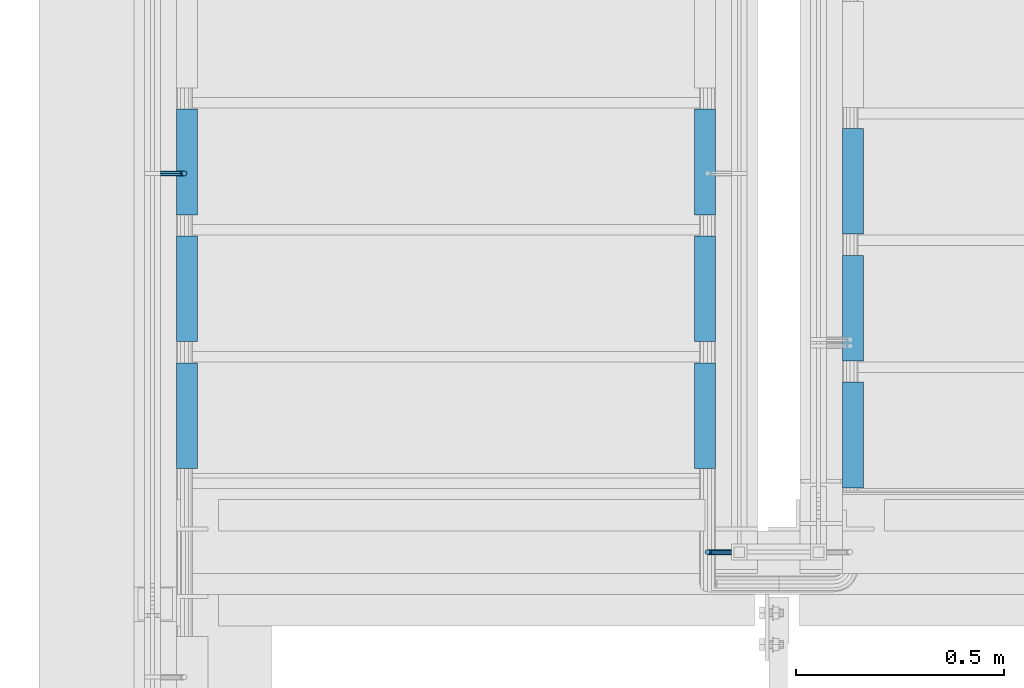
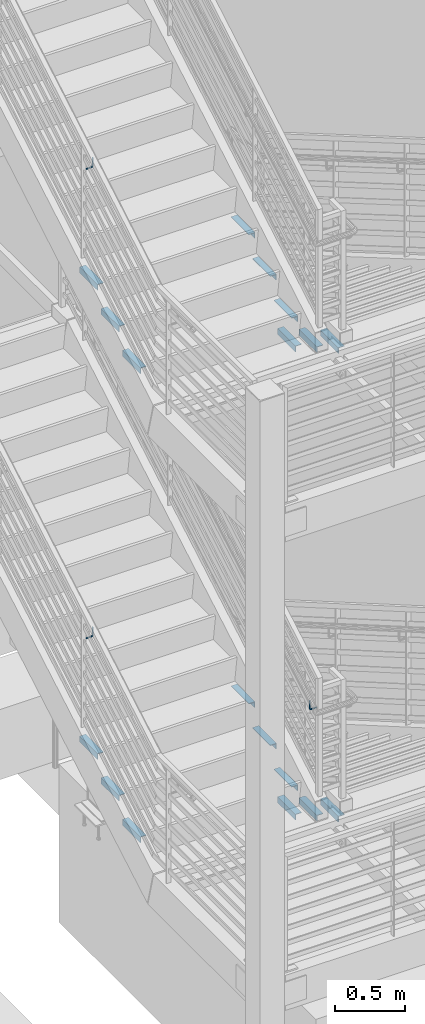
# One storey, part 857 of 1179: 21 beams, 7 elements without a shape of their own.
"""IFC2X3 building model written with IfcOpenShell, lengths in millimetres."""

from ifc_helpers import new_model, si_unit, frame, origin_with_axes, place, context, subcontext, project, spatial, faceted_brep, material, type_object, element, aggregate, save


model = new_model("IFC2X3")

# Units and contexts
model_context = context("Model", 3, precision=1e-05, world=origin_with_axes())
body_context = subcontext(model_context, "Body", "Model", "MODEL_VIEW")
ifc_project = project(units=[si_unit("LENGTHUNIT", "METRE", prefix="MILLI"), si_unit("AREAUNIT", "SQUARE_METRE"), si_unit("VOLUMEUNIT", "CUBIC_METRE"), si_unit("MASSUNIT", "GRAM", prefix="KILO"), si_unit("TIMEUNIT", "SECOND"), si_unit("PLANEANGLEUNIT", "RADIAN"), si_unit("SOLIDANGLEUNIT", "STERADIAN"), si_unit("THERMODYNAMICTEMPERATUREUNIT", "DEGREE_CELSIUS"), si_unit("LUMINOUSINTENSITYUNIT", "LUMEN")], contexts=[model_context])

# Site, building, storey
site_placement = place(None, origin_with_axes())
site = spatial("IfcSite", under=ifc_project, at=site_placement, CompositionType="ELEMENT")
building_placement = place(site_placement, origin_with_axes())
building = spatial("IfcBuilding", under=site, at=building_placement, Name="Undefined", CompositionType="ELEMENT")
storey_placement = place(building_placement, origin_with_axes())
storey = spatial("IfcBuildingStorey", under=building, at=storey_placement, Name="Undefined", CompositionType="ELEMENT", Elevation=0.0)

# Assembly, beams
assembly_1_placement = place(storey_placement, origin_with_axes())
assembly_1 = element("IfcElementAssembly", 1, at=assembly_1_placement, inside=storey, Name="STRINGER", AssemblyPlace="NOTDEFINED", PredefinedType="RIGID_FRAME")
ifc_material = material(Name="STEEL/A36")
beam_type_1 = type_object("IfcBeamType", Name="L2X2X3/16", PredefinedType="NOTDEFINED")
beam_1_placement = place(assembly_1_placement, frame((-3174.9999999819, 32547.8643790635, 6645.27500000067), z_axis=(1.0, 0.0, 0.0), x_axis=(0.0, 1.0, 0.0)))
beam_1 = element("IfcBeam", 2, at=beam_1_placement, type_object=beam_type_1, material=ifc_material, Name="ANGLE", ObjectType="L2X2X3/16", context=body_context, shape_type="Brep", body=[
    faceted_brep([(0.0, 25.3999999999996, -25.4000000000015), (0.0, 25.3999999999996, 25.4000000000015), (254.0, 25.3999999999996, 25.4000000000001), (254.0, 25.3999999999996, -25.4000000000001), (0.0, 20.6374999999998, 25.4000000000015), (254.0, 20.6374999999998, 25.4000000000001), (0.0, 20.6374999999998, -20.6374999999971), (254.0, 20.6374999999998, -20.6374999999998), (0.0, -25.3999999999996, -20.6374999999971), (254.0, -25.3999999999996, -20.6374999999998), (0.0, -25.3999999999996, -25.4000000000015), (254.0, -25.3999999999996, -25.4000000000001)], [[[0, 1, 2, 3]], [[1, 4, 5, 2]], [[4, 6, 7, 5]], [[6, 8, 9, 7]], [[8, 10, 11, 9]], [[10, 0, 3, 11]], [[5, 7, 9, 11, 3, 2]], [[10, 8, 6, 4, 1, 0]]]),
])
beam_2_placement = place(assembly_1_placement, frame((-1930.40000000111, 32801.8643790635, 6645.27499999953), z_axis=(-1.0, 0.0, 0.0), x_axis=(0.0, -1.0, 0.0)))
beam_2 = element("IfcBeam", 3, at=beam_2_placement, type_object=beam_type_1, material=ifc_material, Name="ANGLE", ObjectType="L2X2X3/16", context=body_context, shape_type="Brep", body=[
    faceted_brep([(0.0, 25.3999999999996, -25.4000000000015), (0.0, 25.3999999999996, 25.4000000000015), (254.0, 25.3999999999996, 25.4000000000001), (254.0, 25.3999999999996, -25.4000000000001), (0.0, 20.6374999999998, 25.4000000000015), (254.0, 20.6374999999998, 25.4000000000001), (0.0, 20.6374999999998, -20.6374999999971), (254.0, 20.6374999999998, -20.6374999999998), (0.0, -25.3999999999996, -20.6374999999971), (254.0, -25.3999999999996, -20.6374999999998), (0.0, -25.3999999999996, -25.4000000000015), (254.0, -25.3999999999996, -25.4000000000001)], [[[0, 1, 2, 3]], [[1, 4, 5, 2]], [[4, 6, 7, 5]], [[6, 8, 9, 7]], [[8, 10, 11, 9]], [[10, 0, 3, 11]], [[5, 7, 9, 11, 3, 2]], [[10, 8, 6, 4, 1, 0]]]),
])
beam_3_placement = place(assembly_1_placement, frame((-3174.99999998206, 32243.0643793155, 6467.47500000067), z_axis=(1.0, 0.0, 0.0), x_axis=(0.0, 1.0, 0.0)))
beam_3 = element("IfcBeam", 4, at=beam_3_placement, type_object=beam_type_1, material=ifc_material, Name="ANGLE", ObjectType="L2X2X3/16", context=body_context, shape_type="Brep", body=[
    faceted_brep([(0.0, 25.3999999999996, -25.4000000000015), (0.0, 25.3999999999996, 25.4000000000015), (254.0, 25.3999999999996, 25.4000000000001), (254.0, 25.3999999999996, -25.4000000000001), (0.0, 20.6374999999998, 25.4000000000015), (254.0, 20.6374999999998, 25.4000000000001), (0.0, 20.6374999999998, -20.6374999999971), (254.0, 20.6374999999998, -20.6374999999998), (0.0, -25.3999999999996, -20.6374999999971), (254.0, -25.3999999999996, -20.6374999999998), (0.0, -25.3999999999996, -25.4000000000015), (254.0, -25.3999999999996, -25.4000000000001)], [[[0, 1, 2, 3]], [[1, 4, 5, 2]], [[4, 6, 7, 5]], [[6, 8, 9, 7]], [[8, 10, 11, 9]], [[10, 0, 3, 11]], [[5, 7, 9, 11, 3, 2]], [[10, 8, 6, 4, 1, 0]]]),
])
beam_4_placement = place(assembly_1_placement, frame((-1930.40000000127, 32497.0643793156, 6467.47499999953), z_axis=(-1.0, 0.0, 0.0), x_axis=(0.0, -1.0, 0.0)))
beam_4 = element("IfcBeam", 5, at=beam_4_placement, type_object=beam_type_1, material=ifc_material, Name="ANGLE", ObjectType="L2X2X3/16", context=body_context, shape_type="Brep", body=[
    faceted_brep([(0.0, 25.3999999999996, -25.4000000000015), (0.0, 25.3999999999996, 25.4000000000015), (254.0, 25.3999999999996, 25.4000000000001), (254.0, 25.3999999999996, -25.4000000000001), (0.0, 20.6374999999998, 25.4000000000015), (254.0, 20.6374999999998, 25.4000000000001), (0.0, 20.6374999999998, -20.6374999999971), (254.0, 20.6374999999998, -20.6374999999998), (0.0, -25.3999999999996, -20.6374999999971), (254.0, -25.3999999999996, -20.6374999999998), (0.0, -25.3999999999996, -25.4000000000015), (254.0, -25.3999999999996, -25.4000000000001)], [[[0, 1, 2, 3]], [[1, 4, 5, 2]], [[4, 6, 7, 5]], [[6, 8, 9, 7]], [[8, 10, 11, 9]], [[10, 0, 3, 11]], [[5, 7, 9, 11, 3, 2]], [[10, 8, 6, 4, 1, 0]]]),
])
beam_5_placement = place(assembly_1_placement, frame((-3174.99999998222, 31938.2643795676, 6289.67500000067), z_axis=(1.0, 0.0, 0.0), x_axis=(0.0, 1.0, 0.0)))
beam_5 = element("IfcBeam", 6, at=beam_5_placement, type_object=beam_type_1, material=ifc_material, Name="ANGLE", ObjectType="L2X2X3/16", context=body_context, shape_type="Brep", body=[
    faceted_brep([(0.0, 25.3999999999996, -25.4000000000015), (0.0, 25.3999999999996, 25.4000000000015), (254.0, 25.3999999999996, 25.4000000000001), (254.0, 25.3999999999996, -25.4000000000001), (0.0, 20.6374999999998, 25.4000000000015), (254.0, 20.6374999999998, 25.4000000000001), (0.0, 20.6374999999998, -20.6374999999971), (254.0, 20.6374999999998, -20.6374999999998), (0.0, -25.3999999999996, -20.6374999999971), (254.0, -25.3999999999996, -20.6374999999998), (0.0, -25.3999999999996, -25.4000000000015), (254.0, -25.3999999999996, -25.4000000000001)], [[[0, 1, 2, 3]], [[1, 4, 5, 2]], [[4, 6, 7, 5]], [[6, 8, 9, 7]], [[8, 10, 11, 9]], [[10, 0, 3, 11]], [[5, 7, 9, 11, 3, 2]], [[10, 8, 6, 4, 1, 0]]]),
])
beam_6_placement = place(assembly_1_placement, frame((-1930.40000000143, 32192.2643795676, 6289.67499999953), z_axis=(-1.0, 0.0, 0.0), x_axis=(0.0, -1.0, 0.0)))
beam_6 = element("IfcBeam", 7, at=beam_6_placement, type_object=beam_type_1, material=ifc_material, Name="ANGLE", ObjectType="L2X2X3/16", context=body_context, shape_type="Brep", body=[
    faceted_brep([(0.0, 25.3999999999996, -25.4000000000015), (0.0, 25.3999999999996, 25.4000000000015), (254.0, 25.3999999999996, 25.4000000000001), (254.0, 25.3999999999996, -25.4000000000001), (0.0, 20.6374999999998, 25.4000000000015), (254.0, 20.6374999999998, 25.4000000000001), (0.0, 20.6374999999998, -20.6374999999971), (254.0, 20.6374999999998, -20.6374999999998), (0.0, -25.3999999999996, -20.6374999999971), (254.0, -25.3999999999996, -20.6374999999998), (0.0, -25.3999999999996, -25.4000000000015), (254.0, -25.3999999999996, -25.4000000000001)], [[[0, 1, 2, 3]], [[1, 4, 5, 2]], [[4, 6, 7, 5]], [[6, 8, 9, 7]], [[8, 10, 11, 9]], [[10, 0, 3, 11]], [[5, 7, 9, 11, 3, 2]], [[10, 8, 6, 4, 1, 0]]]),
])
aggregate(assembly_1, [beam_1, beam_2, beam_3, beam_4, beam_5, beam_6])

assembly_2_placement = place(storey_placement, origin_with_axes())
assembly_2 = element("IfcElementAssembly", 8, at=assembly_2_placement, inside=storey, Name="STRINGER", AssemblyPlace="NOTDEFINED", PredefinedType="RIGID_FRAME")
beam_7_placement = place(assembly_2_placement, frame((-1574.79999998749, 31891.9356228005, 5934.07499988841), z_axis=(1.0, 0.0, 0.0), x_axis=(0.0, 1.0, 0.0)))
beam_7 = element("IfcBeam", 9, at=beam_7_placement, type_object=beam_type_1, material=ifc_material, Name="ANGLE", ObjectType="L2X2X3/16", context=body_context, shape_type="Brep", body=[
    faceted_brep([(0.0, 25.3999999999996, -25.4000000000015), (0.0, 25.3999999999996, 25.4000000000015), (254.0, 25.3999999999996, 25.4000000000001), (254.0, 25.3999999999996, -25.4000000000001), (0.0, 20.6374999999998, 25.4000000000015), (254.0, 20.6374999999998, 25.4000000000001), (0.0, 20.6374999999998, -20.6374999999971), (254.0, 20.6374999999998, -20.6374999999998), (0.0, -25.3999999999996, -20.6374999999971), (254.0, -25.3999999999996, -20.6374999999998), (0.0, -25.3999999999996, -25.4000000000015), (254.0, -25.3999999999996, -25.4000000000001)], [[[0, 1, 2, 3]], [[1, 4, 5, 2]], [[4, 6, 7, 5]], [[6, 8, 9, 7]], [[8, 10, 11, 9]], [[10, 0, 3, 11]], [[5, 7, 9, 11, 3, 2]], [[10, 8, 6, 4, 1, 0]]]),
])
beam_8_placement = place(assembly_2_placement, frame((-1574.79999998955, 32196.7356227365, 5756.27499977871), z_axis=(1.0, 0.0, 0.0), x_axis=(0.0, 1.0, 0.0)))
beam_8 = element("IfcBeam", 10, at=beam_8_placement, type_object=beam_type_1, material=ifc_material, Name="ANGLE", ObjectType="L2X2X3/16", context=body_context, shape_type="Brep", body=[
    faceted_brep([(0.0, 25.3999999999996, -25.4000000000015), (0.0, 25.3999999999996, 25.4000000000015), (254.0, 25.3999999999996, 25.4000000000001), (254.0, 25.3999999999996, -25.4000000000001), (0.0, 20.6374999999998, 25.4000000000015), (254.0, 20.6374999999998, 25.4000000000001), (0.0, 20.6374999999998, -20.6374999999971), (254.0, 20.6374999999998, -20.6374999999998), (0.0, -25.3999999999996, -20.6374999999971), (254.0, -25.3999999999996, -20.6374999999998), (0.0, -25.3999999999996, -25.4000000000015), (254.0, -25.3999999999996, -25.4000000000001)], [[[0, 1, 2, 3]], [[1, 4, 5, 2]], [[4, 6, 7, 5]], [[6, 8, 9, 7]], [[8, 10, 11, 9]], [[10, 0, 3, 11]], [[5, 7, 9, 11, 3, 2]], [[10, 8, 6, 4, 1, 0]]]),
])
beam_9_placement = place(assembly_2_placement, frame((-1574.7999999916, 32501.5356226725, 5578.47499966901), z_axis=(1.0, 0.0, 0.0), x_axis=(0.0, 1.0, 0.0)))
beam_9 = element("IfcBeam", 11, at=beam_9_placement, type_object=beam_type_1, material=ifc_material, Name="ANGLE", ObjectType="L2X2X3/16", context=body_context, shape_type="Brep", body=[
    faceted_brep([(0.0, 25.3999999999996, -25.4000000000015), (0.0, 25.3999999999996, 25.4000000000015), (254.0, 25.3999999999996, 25.4000000000001), (254.0, 25.3999999999996, -25.4000000000001), (0.0, 20.6374999999998, 25.4000000000015), (254.0, 20.6374999999998, 25.4000000000001), (0.0, 20.6374999999998, -20.6374999999971), (254.0, 20.6374999999998, -20.6374999999998), (0.0, -25.3999999999996, -20.6374999999971), (254.0, -25.3999999999996, -20.6374999999998), (0.0, -25.3999999999996, -25.4000000000015), (254.0, -25.3999999999996, -25.4000000000001)], [[[0, 1, 2, 3]], [[1, 4, 5, 2]], [[4, 6, 7, 5]], [[6, 8, 9, 7]], [[8, 10, 11, 9]], [[10, 0, 3, 11]], [[5, 7, 9, 11, 3, 2]], [[10, 8, 6, 4, 1, 0]]]),
])
aggregate(assembly_2, [beam_7, beam_8, beam_9])

assembly_3_placement = place(storey_placement, origin_with_axes())
assembly_3 = element("IfcElementAssembly", 12, at=assembly_3_placement, inside=storey, Name="STRINGER", AssemblyPlace="NOTDEFINED", PredefinedType="RIGID_FRAME")
beam_10_placement = place(assembly_3_placement, frame((-1574.79999997975, 31891.8810167866, 1861.92102470219), z_axis=(1.0, 0.0, 0.0), x_axis=(0.0, 1.0, 0.0)))
beam_10 = element("IfcBeam", 13, at=beam_10_placement, type_object=beam_type_1, material=ifc_material, Name="ANGLE", ObjectType="L2X2X3/16", context=body_context, shape_type="Brep", body=[
    faceted_brep([(0.0, 25.3999999999996, -25.4000000000015), (0.0, 25.3999999999996, 25.4000000000015), (254.0, 25.3999999999996, 25.4000000000001), (254.0, 25.3999999999996, -25.4000000000001), (0.0, 20.6374999999998, 25.4000000000015), (254.0, 20.6374999999998, 25.4000000000001), (0.0, 20.6374999999998, -20.6374999999971), (254.0, 20.6374999999998, -20.6374999999998), (0.0, -25.3999999999996, -20.6374999999971), (254.0, -25.3999999999996, -20.6374999999998), (0.0, -25.3999999999996, -25.4000000000015), (254.0, -25.3999999999996, -25.4000000000001)], [[[0, 1, 2, 3]], [[1, 4, 5, 2]], [[4, 6, 7, 5]], [[6, 8, 9, 7]], [[8, 10, 11, 9]], [[10, 0, 3, 11]], [[5, 7, 9, 11, 3, 2]], [[10, 8, 6, 4, 1, 0]]]),
])
beam_11_placement = place(assembly_3_placement, frame((-1574.7999999797, 32196.6811705206, 1685.43913056506), z_axis=(1.0, 0.0, 0.0), x_axis=(0.0, 1.0, 0.0)))
beam_11 = element("IfcBeam", 14, at=beam_11_placement, type_object=beam_type_1, material=ifc_material, Name="ANGLE", ObjectType="L2X2X3/16", context=body_context, shape_type="Brep", body=[
    faceted_brep([(0.0, 25.3999999999996, -25.4000000000015), (0.0, 25.3999999999996, 25.4000000000015), (254.0, 25.3999999999996, 25.4000000000001), (254.0, 25.3999999999996, -25.4000000000001), (0.0, 20.6374999999998, 25.4000000000015), (254.0, 20.6374999999998, 25.4000000000001), (0.0, 20.6374999999998, -20.6374999999971), (254.0, 20.6374999999998, -20.6374999999998), (0.0, -25.3999999999996, -20.6374999999971), (254.0, -25.3999999999996, -20.6374999999998), (0.0, -25.3999999999996, -25.4000000000015), (254.0, -25.3999999999996, -25.4000000000001)], [[[0, 1, 2, 3]], [[1, 4, 5, 2]], [[4, 6, 7, 5]], [[6, 8, 9, 7]], [[8, 10, 11, 9]], [[10, 0, 3, 11]], [[5, 7, 9, 11, 3, 2]], [[10, 8, 6, 4, 1, 0]]]),
])
beam_12_placement = place(assembly_3_placement, frame((-1574.79999997966, 32501.4813242547, 1508.95723642792), z_axis=(1.0, 0.0, 0.0), x_axis=(0.0, 1.0, 0.0)))
beam_12 = element("IfcBeam", 15, at=beam_12_placement, type_object=beam_type_1, material=ifc_material, Name="ANGLE", ObjectType="L2X2X3/16", context=body_context, shape_type="Brep", body=[
    faceted_brep([(0.0, 25.3999999999996, -25.4000000000015), (0.0, 25.3999999999996, 25.4000000000015), (254.0, 25.3999999999996, 25.4000000000001), (254.0, 25.3999999999996, -25.4000000000001), (0.0, 20.6374999999998, 25.4000000000015), (254.0, 20.6374999999998, 25.4000000000001), (0.0, 20.6374999999998, -20.6374999999971), (254.0, 20.6374999999998, -20.6374999999998), (0.0, -25.3999999999996, -20.6374999999971), (254.0, -25.3999999999996, -20.6374999999998), (0.0, -25.3999999999996, -25.4000000000015), (254.0, -25.3999999999996, -25.4000000000001)], [[[0, 1, 2, 3]], [[1, 4, 5, 2]], [[4, 6, 7, 5]], [[6, 8, 9, 7]], [[8, 10, 11, 9]], [[10, 0, 3, 11]], [[5, 7, 9, 11, 3, 2]], [[10, 8, 6, 4, 1, 0]]]),
])
aggregate(assembly_3, [beam_10, beam_11, beam_12])

assembly_4_placement = place(storey_placement, origin_with_axes())
assembly_4 = element("IfcElementAssembly", 16, at=assembly_4_placement, inside=storey, Name="STRINGER", AssemblyPlace="NOTDEFINED", PredefinedType="RIGID_FRAME")
beam_13_placement = place(assembly_4_placement, frame((-3175.00000000384, 32547.9192619495, 2567.78125000058), z_axis=(1.0, 0.0, 0.0), x_axis=(0.0, 1.0, 0.0)))
beam_13 = element("IfcBeam", 17, at=beam_13_placement, type_object=beam_type_1, material=ifc_material, Name="ANGLE", ObjectType="L2X2X3/16", context=body_context, shape_type="Brep", body=[
    faceted_brep([(0.0, 25.3999999999996, -25.4000000000015), (0.0, 25.3999999999996, 25.4000000000015), (254.0, 25.3999999999996, 25.4000000000001), (254.0, 25.3999999999996, -25.4000000000001), (0.0, 20.6374999999998, 25.4000000000015), (254.0, 20.6374999999998, 25.4000000000001), (0.0, 20.6374999999998, -20.6374999999971), (254.0, 20.6374999999998, -20.6374999999998), (0.0, -25.3999999999996, -20.6374999999971), (254.0, -25.3999999999996, -20.6374999999998), (0.0, -25.3999999999996, -25.4000000000015), (254.0, -25.3999999999996, -25.4000000000001)], [[[0, 1, 2, 3]], [[1, 4, 5, 2]], [[4, 6, 7, 5]], [[6, 8, 9, 7]], [[8, 10, 11, 9]], [[10, 0, 3, 11]], [[5, 7, 9, 11, 3, 2]], [[10, 8, 6, 4, 1, 0]]]),
])
beam_14_placement = place(assembly_4_placement, frame((-1930.40000000084, 32801.9192619495, 2567.78125000058), z_axis=(-1.0, 0.0, 0.0), x_axis=(0.0, -1.0, 0.0)))
beam_14 = element("IfcBeam", 18, at=beam_14_placement, type_object=beam_type_1, material=ifc_material, Name="ANGLE", ObjectType="L2X2X3/16", context=body_context, shape_type="Brep", body=[
    faceted_brep([(0.0, 25.3999999999996, -25.4000000000015), (0.0, 25.3999999999996, 25.4000000000015), (254.0, 25.3999999999996, 25.4000000000001), (254.0, 25.3999999999996, -25.4000000000001), (0.0, 20.6374999999998, 25.4000000000015), (254.0, 20.6374999999998, 25.4000000000001), (0.0, 20.6374999999998, -20.6374999999971), (254.0, 20.6374999999998, -20.6374999999998), (0.0, -25.3999999999996, -20.6374999999971), (254.0, -25.3999999999996, -20.6374999999998), (0.0, -25.3999999999996, -25.4000000000015), (254.0, -25.3999999999996, -25.4000000000001)], [[[0, 1, 2, 3]], [[1, 4, 5, 2]], [[4, 6, 7, 5]], [[6, 8, 9, 7]], [[8, 10, 11, 9]], [[10, 0, 3, 11]], [[5, 7, 9, 11, 3, 2]], [[10, 8, 6, 4, 1, 0]]]),
])
beam_15_placement = place(assembly_4_placement, frame((-3175.00000000384, 32243.1192620387, 2391.30416666725), z_axis=(1.0, 0.0, 0.0), x_axis=(0.0, 1.0, 0.0)))
beam_15 = element("IfcBeam", 19, at=beam_15_placement, type_object=beam_type_1, material=ifc_material, Name="ANGLE", ObjectType="L2X2X3/16", context=body_context, shape_type="Brep", body=[
    faceted_brep([(0.0, 25.3999999999996, -25.4000000000015), (0.0, 25.3999999999996, 25.4000000000015), (254.0, 25.3999999999996, 25.4000000000001), (254.0, 25.3999999999996, -25.4000000000001), (0.0, 20.6374999999998, 25.4000000000015), (254.0, 20.6374999999998, 25.4000000000001), (0.0, 20.6374999999998, -20.6374999999971), (254.0, 20.6374999999998, -20.6374999999998), (0.0, -25.3999999999996, -20.6374999999971), (254.0, -25.3999999999996, -20.6374999999998), (0.0, -25.3999999999996, -25.4000000000015), (254.0, -25.3999999999996, -25.4000000000001)], [[[0, 1, 2, 3]], [[1, 4, 5, 2]], [[4, 6, 7, 5]], [[6, 8, 9, 7]], [[8, 10, 11, 9]], [[10, 0, 3, 11]], [[5, 7, 9, 11, 3, 2]], [[10, 8, 6, 4, 1, 0]]]),
])
beam_16_placement = place(assembly_4_placement, frame((-1930.40000000084, 32497.1192620387, 2391.30416666725), z_axis=(-1.0, 0.0, 0.0), x_axis=(0.0, -1.0, 0.0)))
beam_16 = element("IfcBeam", 20, at=beam_16_placement, type_object=beam_type_1, material=ifc_material, Name="ANGLE", ObjectType="L2X2X3/16", context=body_context, shape_type="Brep", body=[
    faceted_brep([(0.0, 25.3999999999996, -25.4000000000015), (0.0, 25.3999999999996, 25.4000000000015), (254.0, 25.3999999999996, 25.4000000000001), (254.0, 25.3999999999996, -25.4000000000001), (0.0, 20.6374999999998, 25.4000000000015), (254.0, 20.6374999999998, 25.4000000000001), (0.0, 20.6374999999998, -20.6374999999971), (254.0, 20.6374999999998, -20.6374999999998), (0.0, -25.3999999999996, -20.6374999999971), (254.0, -25.3999999999996, -20.6374999999998), (0.0, -25.3999999999996, -25.4000000000015), (254.0, -25.3999999999996, -25.4000000000001)], [[[0, 1, 2, 3]], [[1, 4, 5, 2]], [[4, 6, 7, 5]], [[6, 8, 9, 7]], [[8, 10, 11, 9]], [[10, 0, 3, 11]], [[5, 7, 9, 11, 3, 2]], [[10, 8, 6, 4, 1, 0]]]),
])
beam_17_placement = place(assembly_4_placement, frame((-3175.00000000384, 31938.3192621279, 2214.82708333391), z_axis=(1.0, 0.0, 0.0), x_axis=(0.0, 1.0, 0.0)))
beam_17 = element("IfcBeam", 21, at=beam_17_placement, type_object=beam_type_1, material=ifc_material, Name="ANGLE", ObjectType="L2X2X3/16", context=body_context, shape_type="Brep", body=[
    faceted_brep([(0.0, 25.3999999999996, -25.4000000000015), (0.0, 25.3999999999996, 25.4000000000015), (254.0, 25.3999999999996, 25.4000000000001), (254.0, 25.3999999999996, -25.4000000000001), (0.0, 20.6374999999998, 25.4000000000015), (254.0, 20.6374999999998, 25.4000000000001), (0.0, 20.6374999999998, -20.6374999999971), (254.0, 20.6374999999998, -20.6374999999998), (0.0, -25.3999999999996, -20.6374999999971), (254.0, -25.3999999999996, -20.6374999999998), (0.0, -25.3999999999996, -25.4000000000015), (254.0, -25.3999999999996, -25.4000000000001)], [[[0, 1, 2, 3]], [[1, 4, 5, 2]], [[4, 6, 7, 5]], [[6, 8, 9, 7]], [[8, 10, 11, 9]], [[10, 0, 3, 11]], [[5, 7, 9, 11, 3, 2]], [[10, 8, 6, 4, 1, 0]]]),
])
beam_18_placement = place(assembly_4_placement, frame((-1930.40000000084, 32192.3192621279, 2214.82708333391), z_axis=(-1.0, 0.0, 0.0), x_axis=(0.0, -1.0, 0.0)))
beam_18 = element("IfcBeam", 22, at=beam_18_placement, type_object=beam_type_1, material=ifc_material, Name="ANGLE", ObjectType="L2X2X3/16", context=body_context, shape_type="Brep", body=[
    faceted_brep([(0.0, 25.3999999999996, -25.4000000000015), (0.0, 25.3999999999996, 25.4000000000015), (254.0, 25.3999999999996, 25.4000000000001), (254.0, 25.3999999999996, -25.4000000000001), (0.0, 20.6374999999998, 25.4000000000015), (254.0, 20.6374999999998, 25.4000000000001), (0.0, 20.6374999999998, -20.6374999999971), (254.0, 20.6374999999998, -20.6374999999998), (0.0, -25.3999999999996, -20.6374999999971), (254.0, -25.3999999999996, -20.6374999999998), (0.0, -25.3999999999996, -25.4000000000015), (254.0, -25.3999999999996, -25.4000000000001)], [[[0, 1, 2, 3]], [[1, 4, 5, 2]], [[4, 6, 7, 5]], [[6, 8, 9, 7]], [[8, 10, 11, 9]], [[10, 0, 3, 11]], [[5, 7, 9, 11, 3, 2]], [[10, 8, 6, 4, 1, 0]]]),
])
aggregate(assembly_4, [beam_13, beam_14, beam_15, beam_16, beam_17, beam_18])

# Assembly, beam
assembly_5_placement = place(storey_placement, origin_with_axes())
assembly_5 = element("IfcElementAssembly", 23, at=assembly_5_placement, inside=storey, Name="GUARDRAIL", AssemblyPlace="NOTDEFINED", PredefinedType="RIGID_FRAME")
beam_type_2 = type_object("IfcBeamType", PredefinedType="NOTDEFINED")
beam_19_placement = place(assembly_5_placement, frame((-3238.50000225457, 32647.4666677475, 3549.13101115002), z_axis=(0.0, 0.0, 1.0), x_axis=(1.0, 0.0, 0.0)))
beam_19 = element("IfcBeam", 24, at=beam_19_placement, type_object=beam_type_2, material=ifc_material, Name="BRACKET", context=body_context, shape_type="Brep", body=[
    faceted_brep([(0.0, -4.49012806053361, 4.49012806053452), (0.0, 0.0, 6.34999999999991), (0.0, 4.49012806053361, 4.49012806053452), (0.0, 6.34999999999854, 0.0), (0.0, 4.49012806053361, -4.49012806053452), (0.0, 0.0, -6.34999999999991), (0.0, -4.49012806053361, -4.49012806053452), (0.0, -6.34999999999854, 0.0), (44.4500031699827, 0.0, -6.34999999999991), (44.4500031699827, -4.49012806053361, -4.49012806053452), (44.4500031699827, -6.34999999999854, 2.19733919948339e-09), (44.4500031699827, -4.49012806053361, 4.49012806053452), (44.4500031699827, 0.0, 6.34999999999991), (44.4500031699827, 4.49012806053361, 4.49012806053452), (44.4500031699827, 6.34999999999854, 0.0), (44.4500031699827, 4.49012806053361, -4.49012806053452), (53.0450671075391, 4.4901280570557, -2.18708762112465), (53.97500307462, -4.32919478043914e-09, -3.79778396764459), (53.0450671022344, -4.49012806401151, -2.1870876194389), (50.8000030708674, -6.35000000142099, 1.70147734757802), (48.5549390416977, -4.4901280599006, 5.59004231389645), (47.6250030746168, 1.48793333210051e-09, 7.20073866041594), (48.5549390470023, 4.49012806117025, 5.5900423122107), (50.8000030783693, 6.34999999857973, 1.70147734519378), (55.4485256393576, 6.34999999469437, 6.34999990618098), (59.337090604122, 4.49012805180246, 4.10493587545716), (51.5599606707875, 4.49012805866005, 8.59506393599531), (49.9492643188311, -4.54747350886464e-10, 9.52499990463002), (51.5599606615996, -4.4901280624108, 8.59506393379797), (55.4485256263639, -6.35000000530636, 6.34999990307369), (59.337090594938, -4.49012806926839, 4.10493587326664), (60.9477869468905, -1.0153598850593e-08, 3.17499990462466), (61.6401310450869, 4.49012804462109, 12.6999998130159), (63.5000029792477, -1.81098585017025e-08, 12.6999998092651), (57.1500029867496, 6.3499999893902, 12.6999998145698), (52.6598749240178, 4.49012805522943, 12.6999998130159), (50.8000029792477, -3.10683390125632e-09, 12.6999998092651), (52.6598749134085, -4.49012806583778, 12.6999998055144), (57.1500029739432, -6.35000001061053, 12.6999998039605), (61.6401310344776, -4.49012807644976, 12.6999998055144), (63.5000029792478, -6.94672053214163e-08, 76.1999999999989), (61.6401294880566, -4.49012904157644, 73.600247075432), (57.1500014109947, -6.35000090490212, 72.5233941775386), (52.6598733669871, -4.49012891616803, 73.6002471390625), (50.8000029792478, -5.78438630327582e-08, 76.1999999999989), (52.6598734909849, 4.49012713861157, 78.7997530334142), (57.150001576495, 6.34999900334878, 79.8766059321251), (61.6401296120544, 4.49012701602624, 78.7997529714175)], [[[0, 1, 2, 3, 4, 5, 6, 7]], [[6, 5, 8, 9]], [[7, 6, 9, 10]], [[0, 7, 10, 11]], [[1, 0, 11, 12]], [[2, 1, 12, 13]], [[3, 2, 13, 14]], [[4, 3, 14, 15]], [[5, 4, 15, 8]], [[8, 15, 16, 17]], [[9, 8, 17, 18]], [[10, 9, 18, 19]], [[11, 10, 19, 20]], [[12, 11, 20, 21]], [[13, 12, 21, 22]], [[14, 13, 22, 23]], [[15, 14, 23, 16]], [[23, 24, 25, 16]], [[22, 26, 24, 23]], [[21, 27, 26, 22]], [[20, 28, 27, 21]], [[19, 29, 28, 20]], [[18, 30, 29, 19]], [[17, 31, 30, 18]], [[16, 25, 31, 17]], [[25, 32, 33, 31]], [[24, 34, 32, 25]], [[26, 35, 34, 24]], [[27, 36, 35, 26]], [[28, 37, 36, 27]], [[29, 38, 37, 28]], [[30, 39, 38, 29]], [[31, 33, 39, 30]], [[39, 33, 40, 41]], [[38, 39, 41, 42]], [[37, 38, 42, 43]], [[36, 37, 43, 44]], [[35, 36, 44, 45]], [[34, 35, 45, 46]], [[32, 34, 46, 47]], [[33, 32, 47, 40]], [[46, 45, 44, 43, 42, 41, 40, 47]]]),
])
aggregate(assembly_5, [beam_19])

assembly_6_placement = place(storey_placement, origin_with_axes())
assembly_6 = element("IfcElementAssembly", 25, at=assembly_6_placement, inside=storey, Name="GUARDRAIL", AssemblyPlace="NOTDEFINED", PredefinedType="RIGID_FRAME")
beam_20_placement = place(assembly_6_placement, frame((-1866.89999778751, 31737.3000012266, 3022.15083166727), z_axis=(0.0, 0.0, 1.0), x_axis=(-1.0, 0.0, 0.0)))
beam_20 = element("IfcBeam", 26, at=beam_20_placement, type_object=beam_type_2, material=ifc_material, Name="BRACKET", context=body_context, shape_type="Brep", body=[
    faceted_brep([(0.0, -4.49012806053361, 4.49012806053452), (0.0, 0.0, 6.34999999999991), (0.0, 4.49012806053361, 4.49012806053452), (0.0, 6.34999999999854, 0.0), (0.0, 4.49012806053361, -4.49012806053452), (0.0, 0.0, -6.34999999999991), (0.0, -4.49012806053361, -4.49012806053452), (0.0, -6.34999999999854, 0.0), (44.4500031699827, 0.0, -6.34999999999991), (44.4500031699827, -4.49012806053361, -4.49012806053452), (44.4500031699827, -6.34999999999854, 2.19733919948339e-09), (44.4500031699827, -4.49012806053361, 4.49012806053452), (44.4500031699827, 0.0, 6.34999999999991), (44.4500031699827, 4.49012806053361, 4.49012806053452), (44.4500031699827, 6.34999999999854, 0.0), (44.4500031699827, 4.49012806053361, -4.49012806053452), (53.0450671075391, 4.4901280570557, -2.18708762112465), (53.97500307462, -4.32919478043914e-09, -3.79778396764459), (53.0450671022344, -4.49012806401151, -2.1870876194389), (50.8000030708674, -6.35000000142099, 1.70147734757802), (48.5549390416977, -4.4901280599006, 5.59004231389645), (47.6250030746168, 1.48793333210051e-09, 7.20073866041594), (48.5549390470023, 4.49012806117025, 5.5900423122107), (50.8000030783693, 6.34999999857973, 1.70147734519378), (55.4485256393576, 6.34999999469437, 6.34999990618098), (59.337090604122, 4.49012805180246, 4.10493587545716), (51.5599606707875, 4.49012805866005, 8.59506393599531), (49.9492643188311, -4.54747350886464e-10, 9.52499990463002), (51.5599606615996, -4.4901280624108, 8.59506393379797), (55.4485256263639, -6.35000000530636, 6.34999990307369), (59.337090594938, -4.49012806926839, 4.10493587326664), (60.9477869468905, -1.0153598850593e-08, 3.17499990462466), (61.6401310450869, 4.49012804462109, 12.6999998130159), (63.5000029792477, -1.81098585017025e-08, 12.6999998092651), (57.1500029867496, 6.3499999893902, 12.6999998145698), (52.6598749240178, 4.49012805522943, 12.6999998130159), (50.8000029792477, -3.10683390125632e-09, 12.6999998092651), (52.6598749134085, -4.49012806583778, 12.6999998055144), (57.1500029739432, -6.35000001061053, 12.6999998039605), (61.6401310344776, -4.49012807644976, 12.6999998055144), (63.5000029792478, -6.94672053214163e-08, 76.1999999999989), (61.6401296126592, -4.49012700571984, 78.799752974352), (57.1500015702397, -6.34999899351169, 79.8766059398226), (52.6598734915901, -4.49012712951662, 78.7997530460293), (50.8000029792478, -5.78438630327582e-08, 76.1999999999989), (52.6598733663686, 4.49012892461178, 73.6002471520565), (57.1500014002565, 6.35000091383336, 72.5233941857605), (61.6401294874379, 4.49012905126074, 73.6002470787289)], [[[0, 1, 2, 3, 4, 5, 6, 7]], [[6, 5, 8, 9]], [[7, 6, 9, 10]], [[0, 7, 10, 11]], [[1, 0, 11, 12]], [[2, 1, 12, 13]], [[3, 2, 13, 14]], [[4, 3, 14, 15]], [[5, 4, 15, 8]], [[8, 15, 16, 17]], [[9, 8, 17, 18]], [[10, 9, 18, 19]], [[11, 10, 19, 20]], [[12, 11, 20, 21]], [[13, 12, 21, 22]], [[14, 13, 22, 23]], [[15, 14, 23, 16]], [[23, 24, 25, 16]], [[22, 26, 24, 23]], [[21, 27, 26, 22]], [[20, 28, 27, 21]], [[19, 29, 28, 20]], [[18, 30, 29, 19]], [[17, 31, 30, 18]], [[16, 25, 31, 17]], [[25, 32, 33, 31]], [[24, 34, 32, 25]], [[26, 35, 34, 24]], [[27, 36, 35, 26]], [[28, 37, 36, 27]], [[29, 38, 37, 28]], [[30, 39, 38, 29]], [[31, 33, 39, 30]], [[39, 33, 40, 41]], [[38, 39, 41, 42]], [[37, 38, 42, 43]], [[36, 37, 43, 44]], [[35, 36, 44, 45]], [[34, 35, 45, 46]], [[32, 34, 46, 47]], [[33, 32, 47, 40]], [[46, 45, 44, 43, 42, 41, 40, 47]]]),
])
aggregate(assembly_6, [beam_20])

assembly_7_placement = place(storey_placement, origin_with_axes())
assembly_7 = element("IfcElementAssembly", 27, at=assembly_7_placement, inside=storey, Name="GUARDRAIL", AssemblyPlace="NOTDEFINED", PredefinedType="RIGID_FRAME")
beam_21_placement = place(assembly_7_placement, frame((-3238.50000225457, 32647.4666677482, 7627.22629964143), z_axis=(0.0, 0.0, 1.0), x_axis=(1.0, 0.0, 0.0)))
beam_21 = element("IfcBeam", 28, at=beam_21_placement, type_object=beam_type_2, material=ifc_material, Name="BRACKET", context=body_context, shape_type="Brep", body=[
    faceted_brep([(0.0, -4.49012806053361, 4.49012806053452), (0.0, 0.0, 6.34999999999991), (0.0, 4.49012806053361, 4.49012806053452), (0.0, 6.34999999999854, 0.0), (0.0, 4.49012806053361, -4.49012806053452), (0.0, 0.0, -6.34999999999991), (0.0, -4.49012806053361, -4.49012806053452), (0.0, -6.34999999999854, 0.0), (44.4500031699827, 0.0, -6.34999999999991), (44.4500031699827, -4.49012806053361, -4.49012806053452), (44.4500031699827, -6.34999999999854, 2.19733919948339e-09), (44.4500031699827, -4.49012806053361, 4.49012806053452), (44.4500031699827, 0.0, 6.34999999999991), (44.4500031699827, 4.49012806053361, 4.49012806053452), (44.4500031699827, 6.34999999999854, 0.0), (44.4500031699827, 4.49012806053361, -4.49012806053452), (53.0450671075391, 4.4901280570557, -2.18708762112465), (53.97500307462, -4.32919478043914e-09, -3.79778396764459), (53.0450671022344, -4.49012806401151, -2.1870876194389), (50.8000030708674, -6.35000000142099, 1.70147734757802), (48.5549390416977, -4.4901280599006, 5.59004231389645), (47.6250030746168, 1.48793333210051e-09, 7.20073866041594), (48.5549390470023, 4.49012806117025, 5.5900423122107), (50.8000030783693, 6.34999999857973, 1.70147734519378), (55.4485256393576, 6.34999999469437, 6.34999990618098), (59.337090604122, 4.49012805180246, 4.10493587545716), (51.5599606707875, 4.49012805866005, 8.59506393599531), (49.9492643188311, -4.54747350886464e-10, 9.52499990463002), (51.5599606615996, -4.4901280624108, 8.59506393379797), (55.4485256263639, -6.35000000530636, 6.34999990307369), (59.337090594938, -4.49012806926839, 4.10493587326664), (60.9477869468905, -1.0153598850593e-08, 3.17499990462466), (61.6401310450869, 4.49012804462109, 12.6999998130159), (63.5000029792477, -1.81098585017025e-08, 12.6999998092651), (57.1500029867496, 6.3499999893902, 12.6999998145698), (52.6598749240178, 4.49012805522943, 12.6999998130159), (50.8000029792477, -3.10683390125632e-09, 12.6999998092651), (52.6598749134085, -4.49012806583778, 12.6999998055144), (57.1500029739432, -6.35000001061053, 12.6999998039605), (61.6401310344776, -4.49012807644976, 12.6999998055144), (63.5000029792478, -6.94672053214163e-08, 76.1999999999989), (61.6401294880352, -4.49012904147821, 73.5807586715764), (57.1500014109847, -6.35000090467656, 72.4958334126568), (52.6598733669657, -4.49012891602615, 73.5807587357776), (50.8000029792478, -5.78438630327582e-08, 76.1999999999989), (52.6598734909962, 4.49012713825505, 78.8192414384375), (57.1500015765077, 6.34999900287221, 79.9041666981866), (61.6401296120657, 4.49012701564061, 78.8192413758952)], [[[0, 1, 2, 3, 4, 5, 6, 7]], [[6, 5, 8, 9]], [[7, 6, 9, 10]], [[0, 7, 10, 11]], [[1, 0, 11, 12]], [[2, 1, 12, 13]], [[3, 2, 13, 14]], [[4, 3, 14, 15]], [[5, 4, 15, 8]], [[8, 15, 16, 17]], [[9, 8, 17, 18]], [[10, 9, 18, 19]], [[11, 10, 19, 20]], [[12, 11, 20, 21]], [[13, 12, 21, 22]], [[14, 13, 22, 23]], [[15, 14, 23, 16]], [[23, 24, 25, 16]], [[22, 26, 24, 23]], [[21, 27, 26, 22]], [[20, 28, 27, 21]], [[19, 29, 28, 20]], [[18, 30, 29, 19]], [[17, 31, 30, 18]], [[16, 25, 31, 17]], [[25, 32, 33, 31]], [[24, 34, 32, 25]], [[26, 35, 34, 24]], [[27, 36, 35, 26]], [[28, 37, 36, 27]], [[29, 38, 37, 28]], [[30, 39, 38, 29]], [[31, 33, 39, 30]], [[39, 33, 40, 41]], [[38, 39, 41, 42]], [[37, 38, 42, 43]], [[36, 37, 43, 44]], [[35, 36, 44, 45]], [[34, 35, 45, 46]], [[32, 34, 46, 47]], [[33, 32, 47, 40]], [[46, 45, 44, 43, 42, 41, 40, 47]]]),
])
aggregate(assembly_7, [beam_21])

save(model, "model.ifc")
